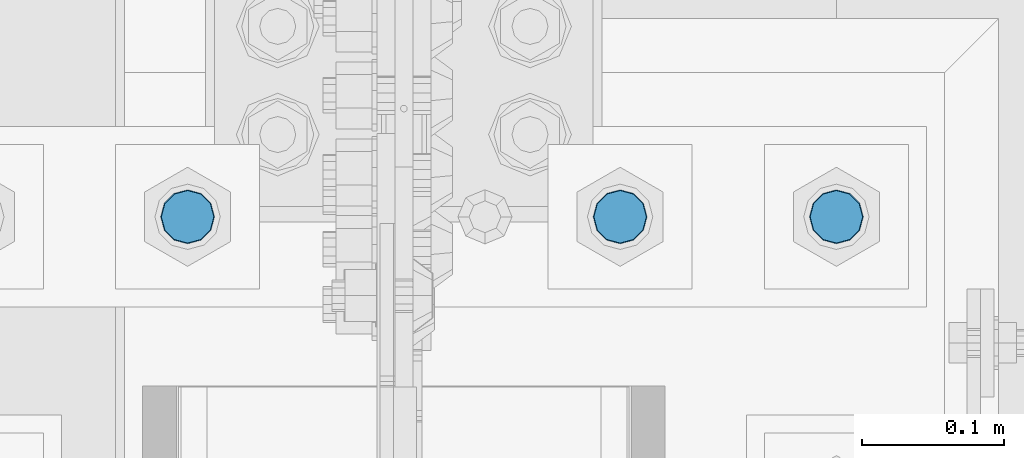
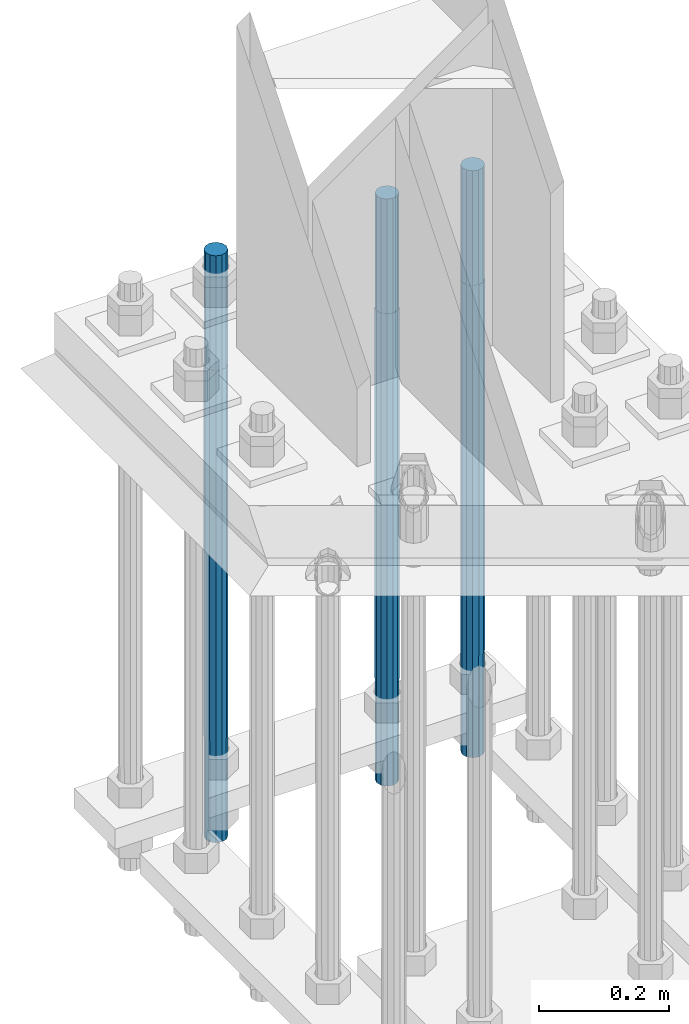
# One storey, part 1415 of 3843: 3 columns, 1 element without a shape of its own.
"""IFC2X3 building model written with IfcOpenShell, lengths in millimetres."""

from ifc_helpers import new_model, si_unit, frame, origin_with_axes, place, context, subcontext, project, spatial, faceted_brep, material, type_object, element, aggregate, save


model = new_model("IFC2X3")

# Units and contexts
model_context = context("Model", 3, precision=1e-05, world=origin_with_axes())
body_context = subcontext(model_context, "Body", "Model", "MODEL_VIEW")
ifc_project = project(units=[si_unit("LENGTHUNIT", "METRE", prefix="MILLI"), si_unit("AREAUNIT", "SQUARE_METRE"), si_unit("VOLUMEUNIT", "CUBIC_METRE"), si_unit("MASSUNIT", "GRAM", prefix="KILO"), si_unit("TIMEUNIT", "SECOND"), si_unit("PLANEANGLEUNIT", "RADIAN"), si_unit("SOLIDANGLEUNIT", "STERADIAN"), si_unit("THERMODYNAMICTEMPERATUREUNIT", "DEGREE_CELSIUS"), si_unit("LUMINOUSINTENSITYUNIT", "LUMEN")], contexts=[model_context])

# Site, building, storey
site_placement = place(None, origin_with_axes())
site = spatial("IfcSite", under=ifc_project, at=site_placement, CompositionType="ELEMENT")
building_placement = place(site_placement, origin_with_axes())
building = spatial("IfcBuilding", under=site, at=building_placement, Name="Undefined", CompositionType="ELEMENT")
storey_placement = place(building_placement, origin_with_axes())
storey = spatial("IfcBuildingStorey", under=building, at=storey_placement, Name="Undefined", CompositionType="ELEMENT", Elevation=0.0)

# Assembly, columns
assembly_placement = place(storey_placement, origin_with_axes())
assembly = element("IfcElementAssembly", 1, at=assembly_placement, inside=storey, Name="TEMPLATE", AssemblyPlace="NOTDEFINED", PredefinedType="RIGID_FRAME")
ifc_material = material(Name="Undefined/F1554-GR.55")
column_type = type_object("IfcColumnType", PredefinedType="NOTDEFINED")
column_1_placement = place(assembly_placement, frame((85953.6, 25920.7, 30022.8), z_axis=(-1.0, 0.0, 0.0), x_axis=(0.0, 0.0, -1.0)))
column_1 = element("IfcColumn", 2, at=column_1_placement, type_object=column_type, material=ifc_material, Name="ANCHOR_ROD", context=body_context, shape_type="Brep", body=[
    faceted_brep([(-215.899999999998, -16.0214699700118, 9.25), (-215.899999999998, -9.25, 16.0214699700155), (-215.899999999998, 0.0, 18.5), (-215.899999999998, 9.25, 16.0214699700155), (-215.899999999998, 16.0214699700118, 9.25), (-215.899999999998, 18.5, 0.0), (-215.899999999998, 16.0214699700118, -9.25), (-215.899999999998, 9.25, -16.0214699700155), (-215.899999999998, 0.0, -18.5), (-215.899999999998, -9.25, -16.0214699700155), (-215.899999999998, -16.0214699700118, -9.25), (-215.899999999998, -18.5, 0.0), (0.0, 18.5, 0.0), (0.0, 16.0214699700118, -9.25), (0.0, 9.25, -16.0214699700155), (0.0, 0.0, -18.5), (0.0, -9.25, -16.0214699700155), (0.0, -16.0214699700118, -9.25), (0.0, -18.5, 0.0), (0.0, -16.0214699700118, 9.25), (0.0, -9.25, 16.0214699700155), (0.0, 0.0, 18.5), (0.0, 9.25, 16.0214699700155), (0.0, 16.0214699700118, 9.25), (0.0, -16.4977839420972, 9.52500000000146), (0.0, -9.52500000000146, 16.4977839420972), (0.0, 0.0, 19.0499989999989), (0.0, 9.52500000000146, 16.4977839420972), (0.0, 16.4977839420972, 9.52500000000146), (0.0, 19.0500000000029, 0.0), (0.0, 16.4977839420972, -9.52500000000146), (0.0, 9.52500000000146, -16.4977839420972), (0.0, 0.0, -19.0499989999989), (0.0, -9.52500000000146, -16.4977839420972), (0.0, -16.4977839420972, -9.52500000000146), (0.0, -19.0500000000029, 0.0), (698.5, -19.0499999999993, 0.0), (698.5, -16.4977839420935, 9.52499999999418), (698.5, -9.52500000000146, 16.4977839420899), (698.5, 0.0, 19.0500000000029), (698.5, 9.52500000000146, 16.4977839420899), (698.5, 16.4977839420935, 9.52499999999418), (698.5, 19.0499999999993, 0.0), (698.5, 16.4977839420935, -9.52499999999418), (698.5, 9.52500000000146, -16.4977839420899), (698.5, 0.0, -19.0500000000029), (698.5, -9.52500000000146, -16.4977839420899), (698.5, -16.4977839420935, -9.52499999999418), (698.5, -9.25, 16.0214699700155), (698.5, 0.0, 18.5), (698.5, 9.25, 16.0214699700155), (698.5, 16.0214699700118, 9.25), (698.5, 18.5, 0.0), (698.5, 16.0214699700118, -9.25), (698.5, 9.25, -16.0214699700155), (698.5, 0.0, -18.5), (698.5, -9.25, -16.0214699700155), (698.5, -16.0214699700118, -9.25), (698.5, -18.5, 0.0), (698.5, -16.0214699700118, 9.25), (889.0, -9.25, -16.0214699700155), (889.0, 0.0, -18.5), (889.0, 9.25, -16.0214699700155), (889.0, 16.0214699700118, -9.25), (889.0, 18.5, 0.0), (889.0, 16.0214699700118, 9.25), (889.0, 9.25, 16.0214699700155), (889.0, 0.0, 18.5), (889.0, -9.25, 16.0214699700155), (889.0, -16.0214699700118, 9.25), (889.0, -18.5, 0.0), (889.0, -16.0214699700118, -9.25)], [[[0, 1, 2, 3, 4, 5, 6, 7, 8, 9, 10, 11]], [[6, 5, 12, 13]], [[7, 6, 13, 14]], [[8, 7, 14, 15]], [[9, 8, 15, 16]], [[10, 9, 16, 17]], [[11, 10, 17, 18]], [[0, 11, 18, 19]], [[1, 0, 19, 20]], [[2, 1, 20, 21]], [[3, 2, 21, 22]], [[4, 3, 22, 23]], [[5, 4, 23, 12]], [[24, 25, 26, 27, 28, 29, 30, 31, 32, 33, 34, 35], [22, 21, 20, 19, 18, 17, 16, 15, 14, 13, 12, 23]], [[24, 35, 36, 37]], [[25, 24, 37, 38]], [[26, 25, 38, 39]], [[27, 26, 39, 40]], [[28, 27, 40, 41]], [[29, 28, 41, 42]], [[30, 29, 42, 43]], [[31, 30, 43, 44]], [[32, 31, 44, 45]], [[33, 32, 45, 46]], [[34, 33, 46, 47]], [[35, 34, 47, 36]], [[46, 45, 44, 43, 42, 41, 40, 39, 38, 37, 36, 47], [48, 49, 50, 51, 52, 53, 54, 55, 56, 57, 58, 59]], [[60, 61, 62, 63, 64, 65, 66, 67, 68, 69, 70, 71]], [[68, 67, 49, 48]], [[69, 68, 48, 59]], [[70, 69, 59, 58]], [[71, 70, 58, 57]], [[60, 71, 57, 56]], [[61, 60, 56, 55]], [[62, 61, 55, 54]], [[63, 62, 54, 53]], [[64, 63, 53, 52]], [[65, 64, 52, 51]], [[66, 65, 51, 50]], [[67, 66, 50, 49]]]),
])
column_2_placement = place(assembly_placement, frame((85801.2, 25920.7, 30022.8), z_axis=(-1.0, 0.0, 0.0), x_axis=(0.0, 0.0, -1.0)))
column_2 = element("IfcColumn", 3, at=column_2_placement, type_object=column_type, material=ifc_material, Name="ANCHOR_ROD", context=body_context, shape_type="Brep", body=[
    faceted_brep([(-215.899999999998, -16.0214699700118, 9.25), (-215.899999999998, -9.25, 16.0214699700155), (-215.899999999998, 0.0, 18.5), (-215.899999999998, 9.25, 16.0214699700155), (-215.899999999998, 16.0214699700118, 9.25), (-215.899999999998, 18.5, 0.0), (-215.899999999998, 16.0214699700118, -9.25), (-215.899999999998, 9.25, -16.0214699700155), (-215.899999999998, 0.0, -18.5), (-215.899999999998, -9.25, -16.0214699700155), (-215.899999999998, -16.0214699700118, -9.25), (-215.899999999998, -18.5, 0.0), (0.0, 18.5, 0.0), (0.0, 16.0214699700118, -9.25), (0.0, 9.25, -16.0214699700155), (0.0, 0.0, -18.5), (0.0, -9.25, -16.0214699700155), (0.0, -16.0214699700118, -9.25), (0.0, -18.5, 0.0), (0.0, -16.0214699700118, 9.25), (0.0, -9.25, 16.0214699700155), (0.0, 0.0, 18.5), (0.0, 9.25, 16.0214699700155), (0.0, 16.0214699700118, 9.25), (0.0, -16.4977839420972, 9.52500000000146), (0.0, -9.52500000000146, 16.4977839420972), (0.0, 0.0, 19.0499989999989), (0.0, 9.52500000000146, 16.4977839420972), (0.0, 16.4977839420972, 9.52500000000146), (0.0, 19.0500000000029, 0.0), (0.0, 16.4977839420972, -9.52500000000146), (0.0, 9.52500000000146, -16.4977839420972), (0.0, 0.0, -19.0499989999989), (0.0, -9.52500000000146, -16.4977839420972), (0.0, -16.4977839420972, -9.52500000000146), (0.0, -19.0500000000029, 0.0), (698.5, -19.0499999999993, 0.0), (698.5, -16.4977839420935, 9.52499999999418), (698.5, -9.52500000000146, 16.4977839420899), (698.5, 0.0, 19.0500000000029), (698.5, 9.52500000000146, 16.4977839420899), (698.5, 16.4977839420935, 9.52499999999418), (698.5, 19.0499999999993, 0.0), (698.5, 16.4977839420935, -9.52499999999418), (698.5, 9.52500000000146, -16.4977839420899), (698.5, 0.0, -19.0500000000029), (698.5, -9.52500000000146, -16.4977839420899), (698.5, -16.4977839420935, -9.52499999999418), (698.5, -9.25, 16.0214699700155), (698.5, 0.0, 18.5), (698.5, 9.25, 16.0214699700155), (698.5, 16.0214699700118, 9.25), (698.5, 18.5, 0.0), (698.5, 16.0214699700118, -9.25), (698.5, 9.25, -16.0214699700155), (698.5, 0.0, -18.5), (698.5, -9.25, -16.0214699700155), (698.5, -16.0214699700118, -9.25), (698.5, -18.5, 0.0), (698.5, -16.0214699700118, 9.25), (889.0, -9.25, -16.0214699700155), (889.0, 0.0, -18.5), (889.0, 9.25, -16.0214699700155), (889.0, 16.0214699700118, -9.25), (889.0, 18.5, 0.0), (889.0, 16.0214699700118, 9.25), (889.0, 9.25, 16.0214699700155), (889.0, 0.0, 18.5), (889.0, -9.25, 16.0214699700155), (889.0, -16.0214699700118, 9.25), (889.0, -18.5, 0.0), (889.0, -16.0214699700118, -9.25)], [[[0, 1, 2, 3, 4, 5, 6, 7, 8, 9, 10, 11]], [[6, 5, 12, 13]], [[7, 6, 13, 14]], [[8, 7, 14, 15]], [[9, 8, 15, 16]], [[10, 9, 16, 17]], [[11, 10, 17, 18]], [[0, 11, 18, 19]], [[1, 0, 19, 20]], [[2, 1, 20, 21]], [[3, 2, 21, 22]], [[4, 3, 22, 23]], [[5, 4, 23, 12]], [[24, 25, 26, 27, 28, 29, 30, 31, 32, 33, 34, 35], [22, 21, 20, 19, 18, 17, 16, 15, 14, 13, 12, 23]], [[24, 35, 36, 37]], [[25, 24, 37, 38]], [[26, 25, 38, 39]], [[27, 26, 39, 40]], [[28, 27, 40, 41]], [[29, 28, 41, 42]], [[30, 29, 42, 43]], [[31, 30, 43, 44]], [[32, 31, 44, 45]], [[33, 32, 45, 46]], [[34, 33, 46, 47]], [[35, 34, 47, 36]], [[46, 45, 44, 43, 42, 41, 40, 39, 38, 37, 36, 47], [48, 49, 50, 51, 52, 53, 54, 55, 56, 57, 58, 59]], [[60, 61, 62, 63, 64, 65, 66, 67, 68, 69, 70, 71]], [[68, 67, 49, 48]], [[69, 68, 48, 59]], [[70, 69, 59, 58]], [[71, 70, 58, 57]], [[60, 71, 57, 56]], [[61, 60, 56, 55]], [[62, 61, 55, 54]], [[63, 62, 54, 53]], [[64, 63, 53, 52]], [[65, 64, 52, 51]], [[66, 65, 51, 50]], [[67, 66, 50, 49]]]),
])
column_3_placement = place(assembly_placement, frame((85496.4, 25920.7, 30022.8), z_axis=(-1.0, 0.0, 0.0), x_axis=(0.0, 0.0, -1.0)))
column_3 = element("IfcColumn", 4, at=column_3_placement, type_object=column_type, material=ifc_material, Name="ANCHOR_ROD", context=body_context, shape_type="Brep", body=[
    faceted_brep([(-215.899999999998, -16.0214699700118, 9.25), (-215.899999999998, -9.25, 16.0214699700155), (-215.899999999998, 0.0, 18.5), (-215.899999999998, 9.25, 16.0214699700155), (-215.899999999998, 16.0214699700118, 9.25), (-215.899999999998, 18.5, 0.0), (-215.899999999998, 16.0214699700118, -9.25), (-215.899999999998, 9.25, -16.0214699700155), (-215.899999999998, 0.0, -18.5), (-215.899999999998, -9.25, -16.0214699700155), (-215.899999999998, -16.0214699700118, -9.25), (-215.899999999998, -18.5, 0.0), (0.0, 18.5, 0.0), (0.0, 16.0214699700118, -9.25), (0.0, 9.25, -16.0214699700155), (0.0, 0.0, -18.5), (0.0, -9.25, -16.0214699700155), (0.0, -16.0214699700118, -9.25), (0.0, -18.5, 0.0), (0.0, -16.0214699700118, 9.25), (0.0, -9.25, 16.0214699700155), (0.0, 0.0, 18.5), (0.0, 9.25, 16.0214699700155), (0.0, 16.0214699700118, 9.25), (0.0, -16.4977839420972, 9.52500000000146), (0.0, -9.52500000000146, 16.4977839420972), (0.0, 0.0, 19.0499989999989), (0.0, 9.52500000000146, 16.4977839420972), (0.0, 16.4977839420972, 9.52500000000146), (0.0, 19.0500000000029, 0.0), (0.0, 16.4977839420972, -9.52500000000146), (0.0, 9.52500000000146, -16.4977839420972), (0.0, 0.0, -19.0499989999989), (0.0, -9.52500000000146, -16.4977839420972), (0.0, -16.4977839420972, -9.52500000000146), (0.0, -19.0500000000029, 0.0), (698.5, -19.0499999999993, 0.0), (698.5, -16.4977839420935, 9.52499999999418), (698.5, -9.52500000000146, 16.4977839420899), (698.5, 0.0, 19.0500000000029), (698.5, 9.52500000000146, 16.4977839420899), (698.5, 16.4977839420935, 9.52499999999418), (698.5, 19.0499999999993, 0.0), (698.5, 16.4977839420935, -9.52499999999418), (698.5, 9.52500000000146, -16.4977839420899), (698.5, 0.0, -19.0500000000029), (698.5, -9.52500000000146, -16.4977839420899), (698.5, -16.4977839420935, -9.52499999999418), (698.5, -9.25, 16.0214699700155), (698.5, 0.0, 18.5), (698.5, 9.25, 16.0214699700155), (698.5, 16.0214699700118, 9.25), (698.5, 18.5, 0.0), (698.5, 16.0214699700118, -9.25), (698.5, 9.25, -16.0214699700155), (698.5, 0.0, -18.5), (698.5, -9.25, -16.0214699700155), (698.5, -16.0214699700118, -9.25), (698.5, -18.5, 0.0), (698.5, -16.0214699700118, 9.25), (889.0, -9.25, -16.0214699700155), (889.0, 0.0, -18.5), (889.0, 9.25, -16.0214699700155), (889.0, 16.0214699700118, -9.25), (889.0, 18.5, 0.0), (889.0, 16.0214699700118, 9.25), (889.0, 9.25, 16.0214699700155), (889.0, 0.0, 18.5), (889.0, -9.25, 16.0214699700155), (889.0, -16.0214699700118, 9.25), (889.0, -18.5, 0.0), (889.0, -16.0214699700118, -9.25)], [[[0, 1, 2, 3, 4, 5, 6, 7, 8, 9, 10, 11]], [[6, 5, 12, 13]], [[7, 6, 13, 14]], [[8, 7, 14, 15]], [[9, 8, 15, 16]], [[10, 9, 16, 17]], [[11, 10, 17, 18]], [[0, 11, 18, 19]], [[1, 0, 19, 20]], [[2, 1, 20, 21]], [[3, 2, 21, 22]], [[4, 3, 22, 23]], [[5, 4, 23, 12]], [[24, 25, 26, 27, 28, 29, 30, 31, 32, 33, 34, 35], [22, 21, 20, 19, 18, 17, 16, 15, 14, 13, 12, 23]], [[24, 35, 36, 37]], [[25, 24, 37, 38]], [[26, 25, 38, 39]], [[27, 26, 39, 40]], [[28, 27, 40, 41]], [[29, 28, 41, 42]], [[30, 29, 42, 43]], [[31, 30, 43, 44]], [[32, 31, 44, 45]], [[33, 32, 45, 46]], [[34, 33, 46, 47]], [[35, 34, 47, 36]], [[46, 45, 44, 43, 42, 41, 40, 39, 38, 37, 36, 47], [48, 49, 50, 51, 52, 53, 54, 55, 56, 57, 58, 59]], [[60, 61, 62, 63, 64, 65, 66, 67, 68, 69, 70, 71]], [[68, 67, 49, 48]], [[69, 68, 48, 59]], [[70, 69, 59, 58]], [[71, 70, 58, 57]], [[60, 71, 57, 56]], [[61, 60, 56, 55]], [[62, 61, 55, 54]], [[63, 62, 54, 53]], [[64, 63, 53, 52]], [[65, 64, 52, 51]], [[66, 65, 51, 50]], [[67, 66, 50, 49]]]),
])
aggregate(assembly, [column_1, column_2, column_3])

save(model, "model.ifc")
